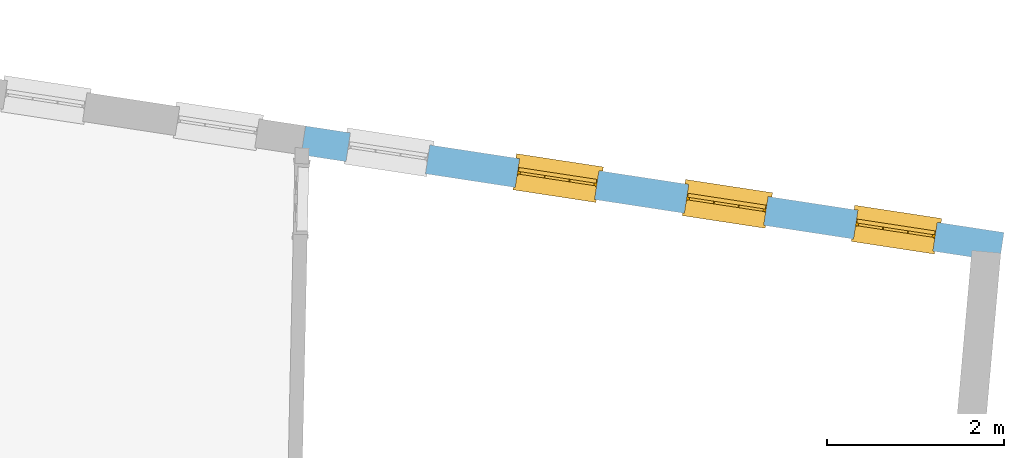
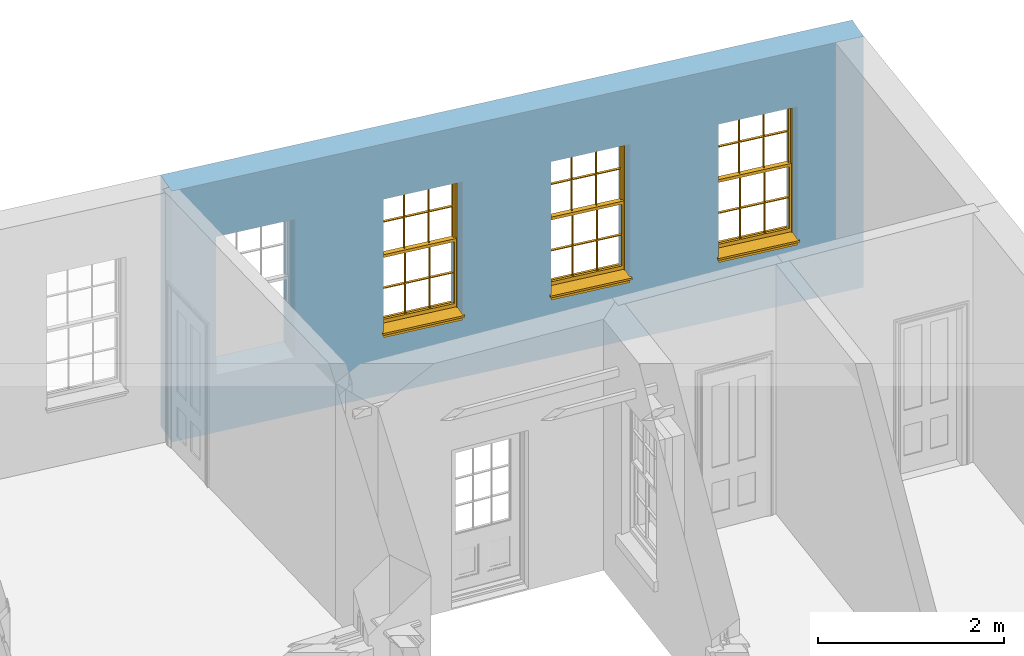
# One storey, part 9 of 12: 3 windows, 4 openings, plus 1 element that does not belong to this part.
"""IFC2X3 building model written with IfcOpenShell, lengths in metres."""

from ifc_helpers import new_model, si_unit, frame, origin, place, context, subcontext, project, spatial, polyline, outline, extrude, faceted_brep, material, layer, layer_set, layer_usage, element, fill, save


model = new_model("IFC2X3")

# Units and contexts
model_context = context("Model", 3, world=origin())
body_context = subcontext(model_context, "Body", "Model", "MODEL_VIEW")
ifc_project = project(units=[si_unit("PLANEANGLEUNIT", "RADIAN"), si_unit("MASSUNIT", "GRAM", prefix="KILO"), si_unit("FORCEUNIT", "NEWTON", prefix="KILO"), si_unit("LENGTHUNIT", "METRE")], contexts=[model_context])

# Site, building, storey
site_placement = place(None, origin())
site = spatial("IfcSite", under=ifc_project, at=site_placement, CompositionType="ELEMENT")
building_placement = place(None, origin())
building = spatial("IfcBuilding", under=site, at=building_placement, Name="Building plot-18", CompositionType="ELEMENT")
storey_placement = place(None, frame((0.0, 0.0, 6.6)))
storey = spatial("IfcBuildingStorey", under=building, at=storey_placement, Name="Floor 1", CompositionType="ELEMENT", Elevation=6.6)

# Wall, openings, windows
ifc_material = material(Name="Masonry")
ifc_layer = layer(ifc_material, 0.33, ventilated=False)
ifc_layer_set = layer_set([ifc_layer], Name="My Wall")
ifc_layer_usage = layer_usage(ifc_layer_set, "AXIS2", "NEGATIVE", 0.08)
wall_placement = place(storey_placement, origin())
wall = element("IfcWallStandardCase", 1, at=wall_placement, inside=storey, material=ifc_layer_usage, Name="exterior", context=body_context, shape_type="SweptSolid", body=[
    extrude(outline(polyline([(101.941775393575, 24.4390124661107), (101.991519769301, 24.7652416755381), (94.0844961381432, 25.9709275645287), (94.0347517624171, 25.6446983551013), (101.941775393575, 24.4390124661107)])), origin(), (0.0, 0.0, 1.0), 3.3),
])
opening_1_placement = place(storey_placement, frame((0.0, 0.0, 0.75)))
opening_1 = element("IfcOpeningElement", 2, at=opening_1_placement, cuts=wall, Name="Opening", ObjectType="Opening", context=body_context, shape_type="SweptSolid", body=[
    extrude(outline(polyline([(101.236692272156, 24.880339960858), (100.337090512825, 25.017513845436), (100.287346137099, 24.6912846360086), (101.186947896429, 24.5541107514306), (101.236692272156, 24.880339960858)])), origin(), (0.0, 0.0, 1.0), 1.82),
])
opening_2_placement = place(storey_placement, frame((0.0, 0.0, 0.75)))
opening_2 = element("IfcOpeningElement", 3, at=opening_2_placement, cuts=wall, Name="Opening", ObjectType="Opening", context=body_context, shape_type="SweptSolid", body=[
    extrude(outline(polyline([(99.3217221994849, 25.1723401498242), (98.4221204401548, 25.3095140344022), (98.3723760644287, 24.9832848249748), (99.2719778237588, 24.8461109403968), (99.3217221994849, 25.1723401498242)])), origin(), (0.0, 0.0, 1.0), 1.82),
])
opening_3_placement = place(storey_placement, frame((0.0, 0.0, 0.75)))
opening_3 = element("IfcOpeningElement", 4, at=opening_3_placement, cuts=wall, Name="Opening", ObjectType="Opening", context=body_context, shape_type="SweptSolid", body=[
    extrude(outline(polyline([(97.4067521268142, 25.4643403387904), (96.5071503674841, 25.6015142233684), (96.4574059917581, 25.275285013941), (97.3570077510882, 25.138111129363), (97.4067521268142, 25.4643403387904)])), origin(), (0.0, 0.0, 1.0), 1.82),
])
opening_4_placement = place(storey_placement, frame((0.0, 0.0, 0.75)))
element("IfcOpeningElement", 5, at=opening_4_placement, cuts=wall, Name="Opening", ObjectType="Opening", context=body_context, shape_type="SweptSolid", body=[
    extrude(outline(polyline([(95.4917820541436, 25.7563405277566), (94.5921802948135, 25.8935144123346), (94.5424359190874, 25.5672852029072), (95.4420376784175, 25.4301113183292), (95.4917820541436, 25.7563405277566)])), origin(), (0.0, 0.0, 1.0), 1.82),
])
window_1_placement = place(storey_placement, frame((101.19900713903, 24.6331966203827, 0.75), z_axis=(0.0, 0.0, 1.0), x_axis=(-0.899601759330096, 0.13717388457793, 0.0)))
window_1 = element("IfcWindow", 6, at=window_1_placement, inside=storey, Name="circulation outside window", OverallHeight=1.82, OverallWidth=0.91, context=body_context, shape_type="Brep", held_by="IfcProductRepresentation", body=[
    faceted_brep([(0.033125, -0.105, 0.975209), (0.01, -0.105, 0.975209), (0.033125, -0.105, 1.376042), (0.876875, -0.105, 0.975209), (0.876875, -0.105, 1.376042), (0.9, -0.105, 0.975209), (0.876875, -0.105, 1.386042), (0.876875, -0.105, 1.786875), (0.9, -0.105, 1.81), (0.033125, -0.105, 1.786875), (0.033125, -0.105, 1.386042), (0.01, -0.105, 1.81), (0.876875, -0.135, 1.376042), (0.876875, -0.135, 0.975209), (0.9, -0.135, 0.937083), (0.033125, -0.135, 1.786875), (0.01, -0.135, 1.81), (0.033125, -0.135, 1.386042), (0.01, -0.135, 0.937083), (0.033125, -0.135, 0.975209), (0.033125, -0.135, 1.376042), (0.876875, -0.135, 1.786875), (0.876875, -0.135, 1.386042), (0.9, -0.135, 1.81), (0.033125, -0.105, 0.937083), (0.01, -0.105, 0.937083), (0.033125, -0.105, 0.53625), (0.876875, -0.105, 0.937083), (0.876875, -0.105, 0.53625), (0.9, -0.105, 0.937083), (0.876875, -0.105, 0.52625), (0.876875, -0.105, 0.125417), (0.9, -0.105, 0.077167), (0.033125, -0.105, 0.125417), (0.033125, -0.105, 0.52625), (0.01, -0.105, 0.077167), (-0.0425, -0.25, 0.01), (-0.0425, -0.3, 0.001667), (0.0, -0.25, 0.01), (0.9525, -0.25, 0.01), (0.91, -0.25, 0.01), (0.9525, -0.3, 0.001667), (-0.02, 0.08, 0.077167), (0.0, 0.08, 0.077167), (-0.02, 0.11, 0.077167), (0.0, -0.06, 0.077167), (0.01, -0.06, 0.077167), (0.91, -0.06, 0.077167), (0.91, 0.08, 0.077167), (0.9, -0.06, 0.077167), (0.93, 0.08, 0.077167), (0.93, 0.11, 0.077167), (0.01, -0.075, 0.975209), (0.9, -0.075, 0.975209), (0.876875, -0.075, 0.125417), (0.876875, -0.075, 0.52625), (0.9, -0.075, 0.077167), (0.876875, -0.075, 0.53625), (0.876875, -0.075, 0.937083), (0.033125, -0.075, 0.125417), (0.01, -0.075, 0.077167), (0.033125, -0.075, 0.52625), (0.033125, -0.075, 0.937083), (0.033125, -0.075, 0.53625), (-0.02, 0.08, 0.052167), (-0.02, 0.11, 0.052167), (0.93, 0.11, 0.052167), (0.93, 0.08, 0.052167), (0.91, 0.08, 0.052167), (0.0, 0.08, 0.052167), (0.91, -0.15, 0.026667), (0.0, -0.15, 0.026667), (-0.0425, -0.3, -0.123333), (0.9525, -0.3, -0.123333), (-0.0425, -0.25, -0.123333), (0.9525, -0.25, -0.123333), (0.01, -0.06, 1.81), (0.9, -0.06, 1.81), (0.0, -0.06, 1.82), (0.91, -0.06, 1.82), (0.01, -0.15, 0.077167), (0.9, -0.15, 0.077167), (0.592292, -0.105, 0.125417), (0.592292, -0.075, 0.125417), (0.317708, -0.075, 0.125417), (0.317708, -0.105, 0.125417), (0.592292, -0.105, 0.53625), (0.317708, -0.105, 0.53625), (0.317708, -0.105, 0.52625), (0.592292, -0.105, 0.52625), (0.592292, -0.075, 0.53625), (0.317708, -0.075, 0.53625), (0.592292, -0.135, 1.386042), (0.592292, -0.105, 1.386042), (0.317708, -0.105, 1.386042), (0.317708, -0.135, 1.386042), (0.317708, -0.135, 1.376042), (0.592292, -0.135, 1.376042), (0.317708, -0.105, 1.376042), (0.592292, -0.105, 1.376042), (0.602292, -0.135, 1.376042), (0.592292, -0.135, 0.975209), (0.602292, -0.135, 0.975209), (0.602292, -0.105, 0.975209), (0.592292, -0.105, 0.975209), (0.602292, -0.105, 1.376042), (0.602292, -0.075, 0.53625), (0.602292, -0.105, 0.53625), (0.317708, -0.075, 0.52625), (0.307708, -0.075, 0.125417), (0.307708, -0.075, 0.52625), (0.602292, -0.075, 0.52625), (0.602292, -0.075, 0.125417), (0.592292, -0.075, 0.52625), (0.307708, -0.075, 0.53625), (0.317708, -0.075, 0.937083), (0.307708, -0.075, 0.937083), (0.602292, -0.075, 0.937083), (0.592292, -0.075, 0.937083), (0.307708, -0.105, 0.52625), (0.307708, -0.105, 0.125417), (0.307708, -0.105, 0.53625), (0.307708, -0.105, 0.937083), (0.592292, -0.105, 0.937083), (0.317708, -0.105, 0.937083), (0.602292, -0.105, 0.937083), (0.602292, -0.105, 0.52625), (0.602292, -0.105, 0.125417), (0.307708, -0.135, 1.386042), (0.307708, -0.135, 1.376042), (0.307708, -0.135, 0.975209), (0.317708, -0.135, 0.975209), (0.317708, -0.135, 1.786875), (0.307708, -0.135, 1.786875), (0.602292, -0.135, 1.786875), (0.592292, -0.135, 1.786875), (0.602292, -0.135, 1.386042), (0.602292, -0.105, 1.386042), (0.307708, -0.105, 1.386042), (0.307708, -0.105, 1.786875), (0.317708, -0.105, 1.786875), (0.592292, -0.105, 1.786875), (0.602292, -0.105, 1.786875), (0.307708, -0.105, 1.376042), (0.317708, -0.105, 0.975209), (0.307708, -0.105, 0.975209), (0.91, -0.15, 1.82), (0.9, -0.15, 1.81), (0.01, -0.15, 1.81), (0.0, -0.15, 1.82), (0.91, -0.25, 0.0), (0.0, -0.25, 0.0), (0.91, 0.08, 0.0), (0.0, 0.08, 0.0)], [[[0, 1, 2]], [[3, 4, 5]], [[6, 7, 8]], [[9, 10, 11]], [[12, 13, 14]], [[15, 16, 17]], [[18, 19, 20]], [[21, 22, 23]], [[24, 25, 26]], [[27, 28, 29]], [[30, 31, 32]], [[33, 34, 35]], [[14, 27, 29]], [[25, 24, 18]], [[36, 37, 38]], [[39, 40, 41]], [[42, 43, 44]], [[45, 46, 43]], [[47, 48, 49]], [[50, 51, 48]], [[1, 0, 52]], [[5, 53, 3]], [[54, 55, 56]], [[57, 58, 53]], [[59, 60, 61]], [[62, 63, 52]], [[48, 43, 46, 49]], [[51, 44, 43, 48]], [[64, 42, 44, 65]], [[65, 44, 51, 66]], [[66, 51, 50, 67]], [[65, 66, 68, 69]], [[60, 56, 49, 46]], [[70, 71, 38, 40]], [[37, 41, 40, 38]], [[37, 72, 73, 41]], [[74, 75, 73, 72]], [[8, 11, 76, 77]], [[76, 78, 79, 77]], [[32, 35, 80, 81]], [[81, 80, 71, 70]], [[82, 83, 84, 85]], [[86, 87, 88, 89]], [[86, 90, 91, 87]], [[92, 93, 94, 95]], [[92, 95, 96, 97]], [[96, 98, 99, 97]], [[100, 97, 101, 102]], [[103, 104, 99, 105]], [[97, 99, 104, 101]], [[102, 103, 105, 100]], [[28, 57, 106, 107]], [[108, 84, 109, 110]], [[111, 112, 83, 113]], [[114, 110, 61, 63]], [[90, 113, 108, 91]], [[115, 91, 114, 116]], [[117, 106, 90, 118]], [[111, 106, 57, 55]], [[119, 110, 109, 120]], [[34, 61, 110, 119]], [[89, 113, 83, 82]], [[88, 108, 113, 89]], [[85, 84, 108, 88]], [[121, 114, 63, 26]], [[122, 116, 114, 121]], [[123, 118, 90, 86]], [[87, 91, 115, 124]], [[107, 106, 117, 125]], [[126, 111, 55, 30]], [[127, 112, 111, 126]], [[126, 30, 28, 107]], [[88, 119, 120, 85]], [[126, 89, 82, 127]], [[125, 123, 86, 107]], [[121, 26, 34, 119]], [[124, 122, 121, 87]], [[128, 17, 20, 129]], [[96, 129, 130, 131]], [[132, 133, 128, 95]], [[134, 135, 92, 136]], [[100, 12, 22, 136]], [[137, 6, 4, 105]], [[94, 138, 139, 140]], [[137, 93, 141, 142]], [[99, 98, 94, 93]], [[143, 2, 10, 138]], [[144, 145, 143, 98]], [[129, 143, 145, 130]], [[20, 2, 143, 129]], [[131, 144, 98, 96]], [[128, 138, 10, 17]], [[133, 139, 138, 128]], [[135, 141, 93, 92]], [[95, 94, 140, 132]], [[22, 6, 137, 136]], [[136, 137, 142, 134]], [[100, 105, 4, 12]], [[107, 86, 89, 126]], [[106, 111, 113, 90]], [[91, 108, 110, 114]], [[87, 121, 119, 88]], [[97, 100, 136, 92]], [[129, 96, 95, 128]], [[98, 143, 138, 94]], [[105, 99, 93, 137]], [[131, 101, 104, 144]], [[124, 115, 118, 123]], [[132, 140, 141, 135]], [[120, 109, 59, 33]], [[15, 9, 139, 133]], [[134, 142, 7, 21]], [[31, 54, 112, 127]], [[36, 74, 72, 37]], [[39, 41, 73, 75]], [[18, 14, 101, 131]], [[23, 16, 132, 135]], [[83, 56, 60, 84]], [[52, 53, 118, 115]], [[53, 52, 144, 104]], [[11, 8, 141, 140]], [[14, 18, 124, 123]], [[2, 1, 11, 10]], [[8, 5, 4, 6]], [[57, 53, 56, 55]], [[60, 52, 63, 61]], [[26, 25, 35, 34]], [[32, 29, 28, 30]], [[14, 23, 22, 12]], [[18, 20, 17, 16]], [[19, 0, 2, 20]], [[17, 10, 9, 15]], [[12, 4, 3, 13]], [[21, 7, 6, 22]], [[27, 58, 57, 28]], [[30, 55, 54, 31]], [[33, 59, 61, 34]], [[26, 63, 62, 24]], [[5, 8, 77, 53]], [[76, 11, 1, 52]], [[46, 45, 78, 76]], [[49, 77, 79, 47]], [[70, 146, 147, 81]], [[71, 80, 148, 149]], [[19, 130, 145, 0]], [[102, 13, 3, 103]], [[116, 122, 24, 62]], [[29, 32, 81, 14]], [[80, 35, 25, 18]], [[60, 46, 76, 52]], [[77, 49, 56, 53]], [[23, 14, 81, 147]], [[16, 148, 80, 18]], [[35, 85, 120]], [[120, 33, 35]], [[127, 82, 32]], [[32, 31, 127]], [[32, 82, 85, 35]], [[102, 101, 14]], [[14, 13, 102]], [[18, 131, 130]], [[130, 19, 18]], [[134, 21, 23]], [[23, 135, 134]], [[16, 15, 133]], [[133, 132, 16]], [[11, 140, 139]], [[139, 9, 11]], [[142, 141, 8]], [[8, 7, 142]], [[23, 147, 148, 16]], [[146, 149, 148, 147]], [[52, 115, 116]], [[116, 62, 52]], [[118, 53, 117]], [[58, 117, 53]], [[27, 125, 117, 58]], [[56, 83, 112]], [[112, 54, 56]], [[109, 84, 60]], [[60, 59, 109]], [[125, 27, 14]], [[14, 123, 125]], [[122, 124, 18]], [[18, 24, 122]], [[145, 144, 52]], [[52, 0, 145]], [[103, 3, 53]], [[53, 104, 103]], [[79, 78, 149, 146]], [[78, 45, 71, 149]], [[146, 70, 47, 79]], [[150, 75, 74, 151]], [[68, 66, 67]], [[48, 68, 67, 50]], [[69, 64, 65]], [[42, 64, 69, 43]], [[69, 68, 152, 153]], [[70, 68, 48, 47]], [[150, 152, 68, 70]], [[43, 69, 71, 45]], [[69, 153, 151, 71]], [[152, 150, 151, 153]], [[38, 151, 74, 36]], [[71, 151, 38]], [[39, 75, 150, 40]], [[40, 150, 70]]]),
])
fill(opening_1, window_1)
window_2_placement = place(storey_placement, frame((99.2840370663591, 24.9251968093489, 0.75), z_axis=(0.0, 0.0, 1.0), x_axis=(-0.899601759330096, 0.13717388457793, 0.0)))
window_2 = element("IfcWindow", 7, at=window_2_placement, inside=storey, Name="circulation outside window", OverallHeight=1.82, OverallWidth=0.91, context=body_context, shape_type="Brep", held_by="IfcProductRepresentation", body=[
    faceted_brep([(0.033125, -0.105, 0.975209), (0.01, -0.105, 0.975209), (0.033125, -0.105, 1.376042), (0.876875, -0.105, 0.975209), (0.876875, -0.105, 1.376042), (0.9, -0.105, 0.975209), (0.876875, -0.105, 1.386042), (0.876875, -0.105, 1.786875), (0.9, -0.105, 1.81), (0.033125, -0.105, 1.786875), (0.033125, -0.105, 1.386042), (0.01, -0.105, 1.81), (0.876875, -0.135, 1.376042), (0.876875, -0.135, 0.975209), (0.9, -0.135, 0.937083), (0.033125, -0.135, 1.786875), (0.01, -0.135, 1.81), (0.033125, -0.135, 1.386042), (0.01, -0.135, 0.937083), (0.033125, -0.135, 0.975209), (0.033125, -0.135, 1.376042), (0.876875, -0.135, 1.786875), (0.876875, -0.135, 1.386042), (0.9, -0.135, 1.81), (0.033125, -0.105, 0.937083), (0.01, -0.105, 0.937083), (0.033125, -0.105, 0.53625), (0.876875, -0.105, 0.937083), (0.876875, -0.105, 0.53625), (0.9, -0.105, 0.937083), (0.876875, -0.105, 0.52625), (0.876875, -0.105, 0.125417), (0.9, -0.105, 0.077167), (0.033125, -0.105, 0.125417), (0.033125, -0.105, 0.52625), (0.01, -0.105, 0.077167), (-0.0425, -0.25, 0.01), (-0.0425, -0.3, 0.001667), (0.0, -0.25, 0.01), (0.9525, -0.25, 0.01), (0.91, -0.25, 0.01), (0.9525, -0.3, 0.001667), (-0.02, 0.08, 0.077167), (0.0, 0.08, 0.077167), (-0.02, 0.11, 0.077167), (0.0, -0.06, 0.077167), (0.01, -0.06, 0.077167), (0.91, -0.06, 0.077167), (0.91, 0.08, 0.077167), (0.9, -0.06, 0.077167), (0.93, 0.08, 0.077167), (0.93, 0.11, 0.077167), (0.01, -0.075, 0.975209), (0.9, -0.075, 0.975209), (0.876875, -0.075, 0.125417), (0.876875, -0.075, 0.52625), (0.9, -0.075, 0.077167), (0.876875, -0.075, 0.53625), (0.876875, -0.075, 0.937083), (0.033125, -0.075, 0.125417), (0.01, -0.075, 0.077167), (0.033125, -0.075, 0.52625), (0.033125, -0.075, 0.937083), (0.033125, -0.075, 0.53625), (-0.02, 0.08, 0.052167), (-0.02, 0.11, 0.052167), (0.93, 0.11, 0.052167), (0.93, 0.08, 0.052167), (0.91, 0.08, 0.052167), (0.0, 0.08, 0.052167), (0.91, -0.15, 0.026667), (0.0, -0.15, 0.026667), (-0.0425, -0.3, -0.123333), (0.9525, -0.3, -0.123333), (-0.0425, -0.25, -0.123333), (0.9525, -0.25, -0.123333), (0.01, -0.06, 1.81), (0.9, -0.06, 1.81), (0.0, -0.06, 1.82), (0.91, -0.06, 1.82), (0.01, -0.15, 0.077167), (0.9, -0.15, 0.077167), (0.592292, -0.105, 0.125417), (0.592292, -0.075, 0.125417), (0.317708, -0.075, 0.125417), (0.317708, -0.105, 0.125417), (0.592292, -0.105, 0.53625), (0.317708, -0.105, 0.53625), (0.317708, -0.105, 0.52625), (0.592292, -0.105, 0.52625), (0.592292, -0.075, 0.53625), (0.317708, -0.075, 0.53625), (0.592292, -0.135, 1.386042), (0.592292, -0.105, 1.386042), (0.317708, -0.105, 1.386042), (0.317708, -0.135, 1.386042), (0.317708, -0.135, 1.376042), (0.592292, -0.135, 1.376042), (0.317708, -0.105, 1.376042), (0.592292, -0.105, 1.376042), (0.602292, -0.135, 1.376042), (0.592292, -0.135, 0.975209), (0.602292, -0.135, 0.975209), (0.602292, -0.105, 0.975209), (0.592292, -0.105, 0.975209), (0.602292, -0.105, 1.376042), (0.602292, -0.075, 0.53625), (0.602292, -0.105, 0.53625), (0.317708, -0.075, 0.52625), (0.307708, -0.075, 0.125417), (0.307708, -0.075, 0.52625), (0.602292, -0.075, 0.52625), (0.602292, -0.075, 0.125417), (0.592292, -0.075, 0.52625), (0.307708, -0.075, 0.53625), (0.317708, -0.075, 0.937083), (0.307708, -0.075, 0.937083), (0.602292, -0.075, 0.937083), (0.592292, -0.075, 0.937083), (0.307708, -0.105, 0.52625), (0.307708, -0.105, 0.125417), (0.307708, -0.105, 0.53625), (0.307708, -0.105, 0.937083), (0.592292, -0.105, 0.937083), (0.317708, -0.105, 0.937083), (0.602292, -0.105, 0.937083), (0.602292, -0.105, 0.52625), (0.602292, -0.105, 0.125417), (0.307708, -0.135, 1.386042), (0.307708, -0.135, 1.376042), (0.307708, -0.135, 0.975209), (0.317708, -0.135, 0.975209), (0.317708, -0.135, 1.786875), (0.307708, -0.135, 1.786875), (0.602292, -0.135, 1.786875), (0.592292, -0.135, 1.786875), (0.602292, -0.135, 1.386042), (0.602292, -0.105, 1.386042), (0.307708, -0.105, 1.386042), (0.307708, -0.105, 1.786875), (0.317708, -0.105, 1.786875), (0.592292, -0.105, 1.786875), (0.602292, -0.105, 1.786875), (0.307708, -0.105, 1.376042), (0.317708, -0.105, 0.975209), (0.307708, -0.105, 0.975209), (0.91, -0.15, 1.82), (0.9, -0.15, 1.81), (0.01, -0.15, 1.81), (0.0, -0.15, 1.82), (0.91, -0.25, 0.0), (0.0, -0.25, 0.0), (0.91, 0.08, 0.0), (0.0, 0.08, 0.0)], [[[0, 1, 2]], [[3, 4, 5]], [[6, 7, 8]], [[9, 10, 11]], [[12, 13, 14]], [[15, 16, 17]], [[18, 19, 20]], [[21, 22, 23]], [[24, 25, 26]], [[27, 28, 29]], [[30, 31, 32]], [[33, 34, 35]], [[14, 27, 29]], [[25, 24, 18]], [[36, 37, 38]], [[39, 40, 41]], [[42, 43, 44]], [[45, 46, 43]], [[47, 48, 49]], [[50, 51, 48]], [[1, 0, 52]], [[5, 53, 3]], [[54, 55, 56]], [[57, 58, 53]], [[59, 60, 61]], [[62, 63, 52]], [[48, 43, 46, 49]], [[51, 44, 43, 48]], [[64, 42, 44, 65]], [[65, 44, 51, 66]], [[66, 51, 50, 67]], [[65, 66, 68, 69]], [[60, 56, 49, 46]], [[70, 71, 38, 40]], [[37, 41, 40, 38]], [[37, 72, 73, 41]], [[74, 75, 73, 72]], [[8, 11, 76, 77]], [[76, 78, 79, 77]], [[32, 35, 80, 81]], [[81, 80, 71, 70]], [[82, 83, 84, 85]], [[86, 87, 88, 89]], [[86, 90, 91, 87]], [[92, 93, 94, 95]], [[92, 95, 96, 97]], [[96, 98, 99, 97]], [[100, 97, 101, 102]], [[103, 104, 99, 105]], [[97, 99, 104, 101]], [[102, 103, 105, 100]], [[28, 57, 106, 107]], [[108, 84, 109, 110]], [[111, 112, 83, 113]], [[114, 110, 61, 63]], [[90, 113, 108, 91]], [[115, 91, 114, 116]], [[117, 106, 90, 118]], [[111, 106, 57, 55]], [[119, 110, 109, 120]], [[34, 61, 110, 119]], [[89, 113, 83, 82]], [[88, 108, 113, 89]], [[85, 84, 108, 88]], [[121, 114, 63, 26]], [[122, 116, 114, 121]], [[123, 118, 90, 86]], [[87, 91, 115, 124]], [[107, 106, 117, 125]], [[126, 111, 55, 30]], [[127, 112, 111, 126]], [[126, 30, 28, 107]], [[88, 119, 120, 85]], [[126, 89, 82, 127]], [[125, 123, 86, 107]], [[121, 26, 34, 119]], [[124, 122, 121, 87]], [[128, 17, 20, 129]], [[96, 129, 130, 131]], [[132, 133, 128, 95]], [[134, 135, 92, 136]], [[100, 12, 22, 136]], [[137, 6, 4, 105]], [[94, 138, 139, 140]], [[137, 93, 141, 142]], [[99, 98, 94, 93]], [[143, 2, 10, 138]], [[144, 145, 143, 98]], [[129, 143, 145, 130]], [[20, 2, 143, 129]], [[131, 144, 98, 96]], [[128, 138, 10, 17]], [[133, 139, 138, 128]], [[135, 141, 93, 92]], [[95, 94, 140, 132]], [[22, 6, 137, 136]], [[136, 137, 142, 134]], [[100, 105, 4, 12]], [[107, 86, 89, 126]], [[106, 111, 113, 90]], [[91, 108, 110, 114]], [[87, 121, 119, 88]], [[97, 100, 136, 92]], [[129, 96, 95, 128]], [[98, 143, 138, 94]], [[105, 99, 93, 137]], [[131, 101, 104, 144]], [[124, 115, 118, 123]], [[132, 140, 141, 135]], [[120, 109, 59, 33]], [[15, 9, 139, 133]], [[134, 142, 7, 21]], [[31, 54, 112, 127]], [[36, 74, 72, 37]], [[39, 41, 73, 75]], [[18, 14, 101, 131]], [[23, 16, 132, 135]], [[83, 56, 60, 84]], [[52, 53, 118, 115]], [[53, 52, 144, 104]], [[11, 8, 141, 140]], [[14, 18, 124, 123]], [[2, 1, 11, 10]], [[8, 5, 4, 6]], [[57, 53, 56, 55]], [[60, 52, 63, 61]], [[26, 25, 35, 34]], [[32, 29, 28, 30]], [[14, 23, 22, 12]], [[18, 20, 17, 16]], [[19, 0, 2, 20]], [[17, 10, 9, 15]], [[12, 4, 3, 13]], [[21, 7, 6, 22]], [[27, 58, 57, 28]], [[30, 55, 54, 31]], [[33, 59, 61, 34]], [[26, 63, 62, 24]], [[5, 8, 77, 53]], [[76, 11, 1, 52]], [[46, 45, 78, 76]], [[49, 77, 79, 47]], [[70, 146, 147, 81]], [[71, 80, 148, 149]], [[19, 130, 145, 0]], [[102, 13, 3, 103]], [[116, 122, 24, 62]], [[29, 32, 81, 14]], [[80, 35, 25, 18]], [[60, 46, 76, 52]], [[77, 49, 56, 53]], [[23, 14, 81, 147]], [[16, 148, 80, 18]], [[35, 85, 120]], [[120, 33, 35]], [[127, 82, 32]], [[32, 31, 127]], [[32, 82, 85, 35]], [[102, 101, 14]], [[14, 13, 102]], [[18, 131, 130]], [[130, 19, 18]], [[134, 21, 23]], [[23, 135, 134]], [[16, 15, 133]], [[133, 132, 16]], [[11, 140, 139]], [[139, 9, 11]], [[142, 141, 8]], [[8, 7, 142]], [[23, 147, 148, 16]], [[146, 149, 148, 147]], [[52, 115, 116]], [[116, 62, 52]], [[118, 53, 117]], [[58, 117, 53]], [[27, 125, 117, 58]], [[56, 83, 112]], [[112, 54, 56]], [[109, 84, 60]], [[60, 59, 109]], [[125, 27, 14]], [[14, 123, 125]], [[122, 124, 18]], [[18, 24, 122]], [[145, 144, 52]], [[52, 0, 145]], [[103, 3, 53]], [[53, 104, 103]], [[79, 78, 149, 146]], [[78, 45, 71, 149]], [[146, 70, 47, 79]], [[150, 75, 74, 151]], [[68, 66, 67]], [[48, 68, 67, 50]], [[69, 64, 65]], [[42, 64, 69, 43]], [[69, 68, 152, 153]], [[70, 68, 48, 47]], [[150, 152, 68, 70]], [[43, 69, 71, 45]], [[69, 153, 151, 71]], [[152, 150, 151, 153]], [[38, 151, 74, 36]], [[71, 151, 38]], [[39, 75, 150, 40]], [[40, 150, 70]]]),
])
fill(opening_2, window_2)
window_3_placement = place(storey_placement, frame((97.3690669936884, 25.2171969983151, 0.75), z_axis=(0.0, 0.0, 1.0), x_axis=(-0.899601759330096, 0.13717388457793, 0.0)))
window_3 = element("IfcWindow", 8, at=window_3_placement, inside=storey, Name="circulation outside window", OverallHeight=1.82, OverallWidth=0.91, context=body_context, shape_type="Brep", held_by="IfcProductRepresentation", body=[
    faceted_brep([(0.033125, -0.105, 0.975209), (0.01, -0.105, 0.975209), (0.033125, -0.105, 1.376042), (0.876875, -0.105, 0.975209), (0.876875, -0.105, 1.376042), (0.9, -0.105, 0.975209), (0.876875, -0.105, 1.386042), (0.876875, -0.105, 1.786875), (0.9, -0.105, 1.81), (0.033125, -0.105, 1.786875), (0.033125, -0.105, 1.386042), (0.01, -0.105, 1.81), (0.876875, -0.135, 1.376042), (0.876875, -0.135, 0.975209), (0.9, -0.135, 0.937083), (0.033125, -0.135, 1.786875), (0.01, -0.135, 1.81), (0.033125, -0.135, 1.386042), (0.01, -0.135, 0.937083), (0.033125, -0.135, 0.975209), (0.033125, -0.135, 1.376042), (0.876875, -0.135, 1.786875), (0.876875, -0.135, 1.386042), (0.9, -0.135, 1.81), (0.033125, -0.105, 0.937083), (0.01, -0.105, 0.937083), (0.033125, -0.105, 0.53625), (0.876875, -0.105, 0.937083), (0.876875, -0.105, 0.53625), (0.9, -0.105, 0.937083), (0.876875, -0.105, 0.52625), (0.876875, -0.105, 0.125417), (0.9, -0.105, 0.077167), (0.033125, -0.105, 0.125417), (0.033125, -0.105, 0.52625), (0.01, -0.105, 0.077167), (-0.0425, -0.25, 0.01), (-0.0425, -0.3, 0.001667), (0.0, -0.25, 0.01), (0.9525, -0.25, 0.01), (0.91, -0.25, 0.01), (0.9525, -0.3, 0.001667), (-0.02, 0.08, 0.077167), (0.0, 0.08, 0.077167), (-0.02, 0.11, 0.077167), (0.0, -0.06, 0.077167), (0.01, -0.06, 0.077167), (0.91, -0.06, 0.077167), (0.91, 0.08, 0.077167), (0.9, -0.06, 0.077167), (0.93, 0.08, 0.077167), (0.93, 0.11, 0.077167), (0.01, -0.075, 0.975209), (0.9, -0.075, 0.975209), (0.876875, -0.075, 0.125417), (0.876875, -0.075, 0.52625), (0.9, -0.075, 0.077167), (0.876875, -0.075, 0.53625), (0.876875, -0.075, 0.937083), (0.033125, -0.075, 0.125417), (0.01, -0.075, 0.077167), (0.033125, -0.075, 0.52625), (0.033125, -0.075, 0.937083), (0.033125, -0.075, 0.53625), (-0.02, 0.08, 0.052167), (-0.02, 0.11, 0.052167), (0.93, 0.11, 0.052167), (0.93, 0.08, 0.052167), (0.91, 0.08, 0.052167), (0.0, 0.08, 0.052167), (0.91, -0.15, 0.026667), (0.0, -0.15, 0.026667), (-0.0425, -0.3, -0.123333), (0.9525, -0.3, -0.123333), (-0.0425, -0.25, -0.123333), (0.9525, -0.25, -0.123333), (0.01, -0.06, 1.81), (0.9, -0.06, 1.81), (0.0, -0.06, 1.82), (0.91, -0.06, 1.82), (0.01, -0.15, 0.077167), (0.9, -0.15, 0.077167), (0.592292, -0.105, 0.125417), (0.592292, -0.075, 0.125417), (0.317708, -0.075, 0.125417), (0.317708, -0.105, 0.125417), (0.592292, -0.105, 0.53625), (0.317708, -0.105, 0.53625), (0.317708, -0.105, 0.52625), (0.592292, -0.105, 0.52625), (0.592292, -0.075, 0.53625), (0.317708, -0.075, 0.53625), (0.592292, -0.135, 1.386042), (0.592292, -0.105, 1.386042), (0.317708, -0.105, 1.386042), (0.317708, -0.135, 1.386042), (0.317708, -0.135, 1.376042), (0.592292, -0.135, 1.376042), (0.317708, -0.105, 1.376042), (0.592292, -0.105, 1.376042), (0.602292, -0.135, 1.376042), (0.592292, -0.135, 0.975209), (0.602292, -0.135, 0.975209), (0.602292, -0.105, 0.975209), (0.592292, -0.105, 0.975209), (0.602292, -0.105, 1.376042), (0.602292, -0.075, 0.53625), (0.602292, -0.105, 0.53625), (0.317708, -0.075, 0.52625), (0.307708, -0.075, 0.125417), (0.307708, -0.075, 0.52625), (0.602292, -0.075, 0.52625), (0.602292, -0.075, 0.125417), (0.592292, -0.075, 0.52625), (0.307708, -0.075, 0.53625), (0.317708, -0.075, 0.937083), (0.307708, -0.075, 0.937083), (0.602292, -0.075, 0.937083), (0.592292, -0.075, 0.937083), (0.307708, -0.105, 0.52625), (0.307708, -0.105, 0.125417), (0.307708, -0.105, 0.53625), (0.307708, -0.105, 0.937083), (0.592292, -0.105, 0.937083), (0.317708, -0.105, 0.937083), (0.602292, -0.105, 0.937083), (0.602292, -0.105, 0.52625), (0.602292, -0.105, 0.125417), (0.307708, -0.135, 1.386042), (0.307708, -0.135, 1.376042), (0.307708, -0.135, 0.975209), (0.317708, -0.135, 0.975209), (0.317708, -0.135, 1.786875), (0.307708, -0.135, 1.786875), (0.602292, -0.135, 1.786875), (0.592292, -0.135, 1.786875), (0.602292, -0.135, 1.386042), (0.602292, -0.105, 1.386042), (0.307708, -0.105, 1.386042), (0.307708, -0.105, 1.786875), (0.317708, -0.105, 1.786875), (0.592292, -0.105, 1.786875), (0.602292, -0.105, 1.786875), (0.307708, -0.105, 1.376042), (0.317708, -0.105, 0.975209), (0.307708, -0.105, 0.975209), (0.91, -0.15, 1.82), (0.9, -0.15, 1.81), (0.01, -0.15, 1.81), (0.0, -0.15, 1.82), (0.91, -0.25, 0.0), (0.0, -0.25, 0.0), (0.91, 0.08, 0.0), (0.0, 0.08, 0.0)], [[[0, 1, 2]], [[3, 4, 5]], [[6, 7, 8]], [[9, 10, 11]], [[12, 13, 14]], [[15, 16, 17]], [[18, 19, 20]], [[21, 22, 23]], [[24, 25, 26]], [[27, 28, 29]], [[30, 31, 32]], [[33, 34, 35]], [[14, 27, 29]], [[25, 24, 18]], [[36, 37, 38]], [[39, 40, 41]], [[42, 43, 44]], [[45, 46, 43]], [[47, 48, 49]], [[50, 51, 48]], [[1, 0, 52]], [[5, 53, 3]], [[54, 55, 56]], [[57, 58, 53]], [[59, 60, 61]], [[62, 63, 52]], [[48, 43, 46, 49]], [[51, 44, 43, 48]], [[64, 42, 44, 65]], [[65, 44, 51, 66]], [[66, 51, 50, 67]], [[65, 66, 68, 69]], [[60, 56, 49, 46]], [[70, 71, 38, 40]], [[37, 41, 40, 38]], [[37, 72, 73, 41]], [[74, 75, 73, 72]], [[8, 11, 76, 77]], [[76, 78, 79, 77]], [[32, 35, 80, 81]], [[81, 80, 71, 70]], [[82, 83, 84, 85]], [[86, 87, 88, 89]], [[86, 90, 91, 87]], [[92, 93, 94, 95]], [[92, 95, 96, 97]], [[96, 98, 99, 97]], [[100, 97, 101, 102]], [[103, 104, 99, 105]], [[97, 99, 104, 101]], [[102, 103, 105, 100]], [[28, 57, 106, 107]], [[108, 84, 109, 110]], [[111, 112, 83, 113]], [[114, 110, 61, 63]], [[90, 113, 108, 91]], [[115, 91, 114, 116]], [[117, 106, 90, 118]], [[111, 106, 57, 55]], [[119, 110, 109, 120]], [[34, 61, 110, 119]], [[89, 113, 83, 82]], [[88, 108, 113, 89]], [[85, 84, 108, 88]], [[121, 114, 63, 26]], [[122, 116, 114, 121]], [[123, 118, 90, 86]], [[87, 91, 115, 124]], [[107, 106, 117, 125]], [[126, 111, 55, 30]], [[127, 112, 111, 126]], [[126, 30, 28, 107]], [[88, 119, 120, 85]], [[126, 89, 82, 127]], [[125, 123, 86, 107]], [[121, 26, 34, 119]], [[124, 122, 121, 87]], [[128, 17, 20, 129]], [[96, 129, 130, 131]], [[132, 133, 128, 95]], [[134, 135, 92, 136]], [[100, 12, 22, 136]], [[137, 6, 4, 105]], [[94, 138, 139, 140]], [[137, 93, 141, 142]], [[99, 98, 94, 93]], [[143, 2, 10, 138]], [[144, 145, 143, 98]], [[129, 143, 145, 130]], [[20, 2, 143, 129]], [[131, 144, 98, 96]], [[128, 138, 10, 17]], [[133, 139, 138, 128]], [[135, 141, 93, 92]], [[95, 94, 140, 132]], [[22, 6, 137, 136]], [[136, 137, 142, 134]], [[100, 105, 4, 12]], [[107, 86, 89, 126]], [[106, 111, 113, 90]], [[91, 108, 110, 114]], [[87, 121, 119, 88]], [[97, 100, 136, 92]], [[129, 96, 95, 128]], [[98, 143, 138, 94]], [[105, 99, 93, 137]], [[131, 101, 104, 144]], [[124, 115, 118, 123]], [[132, 140, 141, 135]], [[120, 109, 59, 33]], [[15, 9, 139, 133]], [[134, 142, 7, 21]], [[31, 54, 112, 127]], [[36, 74, 72, 37]], [[39, 41, 73, 75]], [[18, 14, 101, 131]], [[23, 16, 132, 135]], [[83, 56, 60, 84]], [[52, 53, 118, 115]], [[53, 52, 144, 104]], [[11, 8, 141, 140]], [[14, 18, 124, 123]], [[2, 1, 11, 10]], [[8, 5, 4, 6]], [[57, 53, 56, 55]], [[60, 52, 63, 61]], [[26, 25, 35, 34]], [[32, 29, 28, 30]], [[14, 23, 22, 12]], [[18, 20, 17, 16]], [[19, 0, 2, 20]], [[17, 10, 9, 15]], [[12, 4, 3, 13]], [[21, 7, 6, 22]], [[27, 58, 57, 28]], [[30, 55, 54, 31]], [[33, 59, 61, 34]], [[26, 63, 62, 24]], [[5, 8, 77, 53]], [[76, 11, 1, 52]], [[46, 45, 78, 76]], [[49, 77, 79, 47]], [[70, 146, 147, 81]], [[71, 80, 148, 149]], [[19, 130, 145, 0]], [[102, 13, 3, 103]], [[116, 122, 24, 62]], [[29, 32, 81, 14]], [[80, 35, 25, 18]], [[60, 46, 76, 52]], [[77, 49, 56, 53]], [[23, 14, 81, 147]], [[16, 148, 80, 18]], [[35, 85, 120]], [[120, 33, 35]], [[127, 82, 32]], [[32, 31, 127]], [[32, 82, 85, 35]], [[102, 101, 14]], [[14, 13, 102]], [[18, 131, 130]], [[130, 19, 18]], [[134, 21, 23]], [[23, 135, 134]], [[16, 15, 133]], [[133, 132, 16]], [[11, 140, 139]], [[139, 9, 11]], [[142, 141, 8]], [[8, 7, 142]], [[23, 147, 148, 16]], [[146, 149, 148, 147]], [[52, 115, 116]], [[116, 62, 52]], [[118, 53, 117]], [[58, 117, 53]], [[27, 125, 117, 58]], [[56, 83, 112]], [[112, 54, 56]], [[109, 84, 60]], [[60, 59, 109]], [[125, 27, 14]], [[14, 123, 125]], [[122, 124, 18]], [[18, 24, 122]], [[145, 144, 52]], [[52, 0, 145]], [[103, 3, 53]], [[53, 104, 103]], [[79, 78, 149, 146]], [[78, 45, 71, 149]], [[146, 70, 47, 79]], [[150, 75, 74, 151]], [[68, 66, 67]], [[48, 68, 67, 50]], [[69, 64, 65]], [[42, 64, 69, 43]], [[69, 68, 152, 153]], [[70, 68, 48, 47]], [[150, 152, 68, 70]], [[43, 69, 71, 45]], [[69, 153, 151, 71]], [[152, 150, 151, 153]], [[38, 151, 74, 36]], [[71, 151, 38]], [[39, 75, 150, 40]], [[40, 150, 70]]]),
])
fill(opening_3, window_3)

save(model, "model.ifc")
